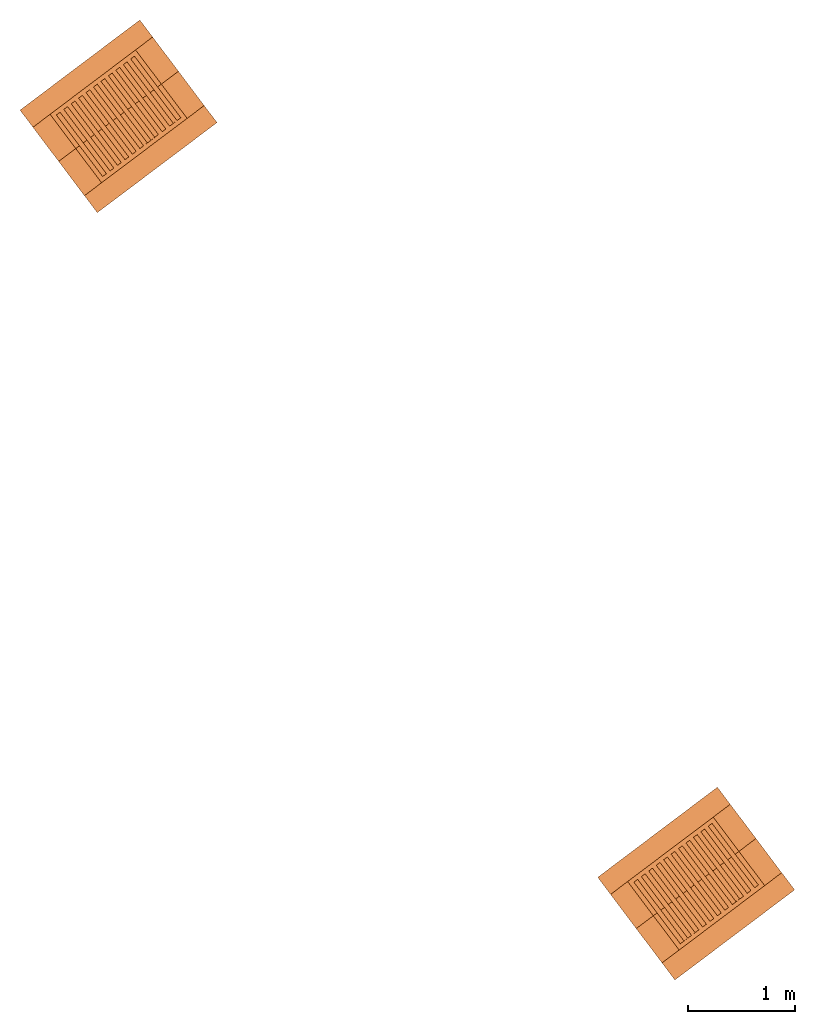
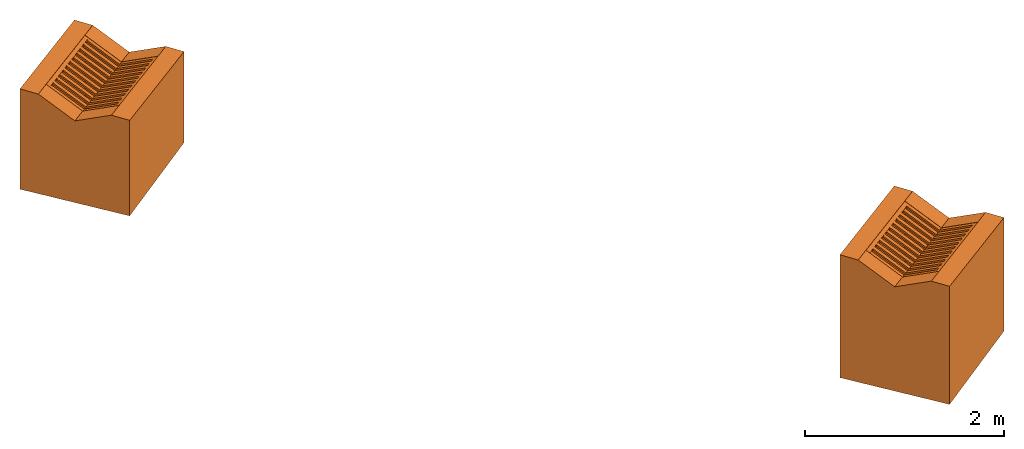
"""IFC2X3 building model written with IfcOpenShell, lengths in metres."""

from ifc_helpers import new_model, entity, si_unit, converted_unit, direction, frame, origin_with_axes, place, context, project, spatial, faceted_brep, element, save


model = new_model("IFC2X3")

# Units and contexts
model_context = context("Model", 3, precision=1e-05, world=origin_with_axes(), true_north=direction((0.0, 1.0)))
ifc_project = project(units=[si_unit("LENGTHUNIT", "METRE"), converted_unit("PLANEANGLEUNIT", "Degree", entity("IfcPlaneAngleMeasure", 0.015707963), si_unit("PLANEANGLEUNIT", "RADIAN"), dimensions=[0, 0, 0, 0, 0, 0, 0]), si_unit("AREAUNIT", "SQUARE_METRE"), si_unit("VOLUMEUNIT", "CUBIC_METRE"), si_unit("MASSUNIT", "GRAM", prefix="KILO")], contexts=[model_context])

# Site, building, storeys
site_placement = place(None, frame((0.0, 0.0, 0.0), z_axis=(0.0, 0.0, 1.0), x_axis=(1.0, 6.12323399573677e-17, 0.0)))
site = spatial("IfcSite", under=ifc_project, at=site_placement, CompositionType="ELEMENT")
building_placement = place(None, frame((0.0, 0.0, 0.0), z_axis=(0.0, 0.0, 1.0), x_axis=(1.0, 6.12323399573677e-17, 0.0)))
building = spatial("IfcBuilding", under=site, at=building_placement, Name="(G0) Grupo 0", CompositionType="ELEMENT")
storey_1_placement = place(building_placement, origin_with_axes())
storey_1 = spatial("IfcBuildingStorey", under=building, at=storey_1_placement, Name="(E2)", CompositionType="ELEMENT")
storey_2_placement = place(storey_1_placement, origin_with_axes())
storey_2 = spatial("IfcBuildingStorey", under=storey_1, at=storey_2_placement, CompositionType="PARTIAL")
storey_3_placement = place(storey_2_placement, origin_with_axes())
storey_3 = spatial("IfcBuildingStorey", under=storey_2, at=storey_3_placement, CompositionType="PARTIAL")

# Proxies
proxy_1_placement = place(storey_3_placement, frame((13.447, -4.29, 174.55), z_axis=(0.0, 0.0, 1.0), x_axis=(1.0, 0.0, 0.0)))
element("IfcBuildingElementProxy", 1, at=proxy_1_placement, inside=storey_3, Name="P1", CompositionType="ELEMENT", context=model_context, shape_type="Brep", body=[
    faceted_brep([(1.118, 1.801, 0.2), (1.238, 1.641, 0.2), (1.238, 1.641, 1.445), (1.118, 1.801, 1.455), (1.118, 1.801, 0.0), (1.238, 1.641, 0.0), (1.079, 1.521, 1.453), (1.079, 1.521, 0.2), (1.479, 1.322, 0.2), (1.479, 1.322, 1.225), (1.479, 1.322, 0.0), (1.319, 1.201, 1.233), (1.319, 1.201, 0.2), (1.719, 1.002, 0.2), (1.719, 1.002, 1.405), (1.719, 1.002, 0.0), (1.56, 0.882, 1.413), (1.56, 0.882, 0.2), (1.84, 0.842, 0.2), (1.84, 0.842, 1.395), (1.84, 0.842, 0.0), (0.721, 0.0, 0.2), (0.721, 0.0, 1.451), (0.721, 0.0, 0.0), (0.761, 0.28, 1.453), (0.761, 0.28, 0.2), (0.601, 0.16, 0.2), (0.601, 0.16, 1.461), (0.601, 0.16, 0.0), (0.36, 0.48, 0.2), (0.36, 0.48, 1.281), (0.36, 0.48, 0.0), (0.52, 0.6, 1.273), (0.52, 0.6, 0.2), (0.12, 0.799, 0.2), (0.12, 0.799, 1.501), (0.12, 0.799, 0.0), (0.28, 0.92, 1.493), (0.28, 0.92, 0.2), (0.0, 0.959, 0.2), (0.0, 0.959, 1.511), (0.0, 0.959, 0.0), (0.92, 0.901, 0.0), (0.92, 0.901, 0.2)], [[[0, 1, 2, 3]], [[4, 5, 1, 0]], [[6, 7, 7, 6]], [[2, 6, 6, 3]], [[1, 8, 9, 2]], [[5, 10, 8, 1]], [[11, 12, 7, 6]], [[9, 11, 6, 2]], [[8, 13, 14, 9]], [[10, 15, 13, 8]], [[16, 17, 12, 11]], [[14, 16, 11, 9]], [[13, 18, 19, 14]], [[15, 20, 18, 13]], [[16, 17, 17, 16]], [[19, 16, 16, 14]], [[18, 21, 22, 19]], [[20, 23, 21, 18]], [[24, 25, 17, 16]], [[22, 24, 16, 19]], [[21, 26, 27, 22]], [[23, 28, 26, 21]], [[24, 25, 25, 24]], [[27, 24, 24, 22]], [[26, 29, 30, 27]], [[28, 31, 29, 26]], [[32, 33, 25, 24]], [[30, 32, 24, 27]], [[29, 34, 35, 30]], [[31, 36, 34, 29]], [[37, 38, 33, 32]], [[35, 37, 32, 30]], [[34, 39, 40, 35]], [[36, 41, 39, 34]], [[37, 38, 38, 37]], [[40, 37, 37, 35]], [[39, 0, 3, 40]], [[41, 4, 0, 39]], [[6, 7, 38, 37]], [[3, 6, 37, 40]], [[42, 5, 4]], [[43, 7, 12]], [[42, 10, 5]], [[43, 12, 17]], [[42, 15, 10]], [[42, 20, 15]], [[43, 17, 25]], [[42, 23, 20]], [[42, 28, 23]], [[43, 25, 33]], [[42, 31, 28]], [[43, 33, 38]], [[42, 36, 31]], [[42, 41, 36]], [[43, 38, 7]], [[42, 4, 41]]], orient=[[False], [False], [False], [False], [False], [False], [False], [False], [False], [False], [False], [False], [False], [False], [False], [False], [False], [False], [False], [False], [False], [False], [False], [False], [False], [False], [False], [False], [False], [False], [False], [False], [False], [False], [False], [False], [False], [False], [False], [False], [False], [False], [False], [False], [False], [False], [False], [False], [False], [False], [False], [False], [False], [False], [False], [False]]),
])
proxy_2_placement = place(storey_3_placement, frame((13.727, -4.01, 175.761), z_axis=(0.0, 0.0, 1.0), x_axis=(1.0, 0.0, 0.0)))
element("IfcBuildingElementProxy", 2, at=proxy_2_placement, inside=storey_3, Name="P1 (Rejilla)", ObjectType="REJILLA", CompositionType="ELEMENT", context=model_context, shape_type="Brep", body=[
    faceted_brep([(1.256, 0.634, 0.182), (1.256, 0.634, 0.162), (1.28, 0.602, 0.18), (1.28, 0.602, 0.2), (0.481, 0.0, 0.22), (0.457, 0.032, 0.202), (0.457, 0.032, 0.222), (0.481, 0.0, 0.24), (0.799, 1.241, 0.24), (0.799, 1.241, 0.22), (0.823, 1.209, 0.198), (0.823, 1.209, 0.218), (0.024, 0.608, 0.238), (0.0, 0.64, 0.26), (0.0, 0.64, 0.28), (0.024, 0.608, 0.258), (1.004, 0.895, 0.02), (1.004, 0.895, 0.0), (1.039, 0.921, 0.0), (1.039, 0.921, 0.02), (1.221, 0.608, 0.162), (1.221, 0.608, 0.182), (0.788, 1.183, 0.218), (0.788, 1.183, 0.198), (0.935, 0.843, 0.023), (0.935, 0.843, 0.003), (0.97, 0.869, 0.003), (0.97, 0.869, 0.023), (1.186, 0.582, 0.165), (1.151, 0.555, 0.165), (1.151, 0.555, 0.185), (1.186, 0.582, 0.185), (0.718, 1.131, 0.221), (0.718, 1.131, 0.201), (0.753, 1.157, 0.201), (0.753, 1.157, 0.221), (0.865, 0.791, 0.027), (0.865, 0.791, 0.007), (0.9, 0.817, 0.007), (0.9, 0.817, 0.027), (1.117, 0.529, 0.169), (1.082, 0.503, 0.169), (1.082, 0.503, 0.189), (1.117, 0.529, 0.189), (0.649, 1.078, 0.225), (0.649, 1.078, 0.205), (0.684, 1.104, 0.205), (0.684, 1.104, 0.225), (0.796, 0.738, 0.03), (0.796, 0.738, 0.01), (0.831, 0.765, 0.01), (0.831, 0.765, 0.03), (1.047, 0.477, 0.172), (1.012, 0.451, 0.172), (1.012, 0.451, 0.192), (1.047, 0.477, 0.192), (0.579, 1.026, 0.228), (0.579, 1.026, 0.208), (0.614, 1.052, 0.208), (0.614, 1.052, 0.228), (0.726, 0.686, 0.034), (0.726, 0.686, 0.014), (0.761, 0.712, 0.014), (0.761, 0.712, 0.034), (0.978, 0.425, 0.176), (0.943, 0.398, 0.176), (0.943, 0.398, 0.196), (0.978, 0.425, 0.196), (0.51, 0.974, 0.232), (0.51, 0.974, 0.212), (0.545, 1.0, 0.212), (0.545, 1.0, 0.232), (0.657, 0.634, 0.037), (0.657, 0.634, 0.017), (0.692, 0.66, 0.017), (0.692, 0.66, 0.037), (0.908, 0.372, 0.179), (0.874, 0.346, 0.179), (0.874, 0.346, 0.199), (0.908, 0.372, 0.199), (0.44, 0.921, 0.235), (0.44, 0.921, 0.215), (0.475, 0.948, 0.215), (0.475, 0.948, 0.235), (0.588, 0.581, 0.041), (0.588, 0.581, 0.021), (0.622, 0.608, 0.021), (0.622, 0.608, 0.041), (0.839, 0.32, 0.183), (0.804, 0.294, 0.183), (0.804, 0.294, 0.203), (0.839, 0.32, 0.203), (0.371, 0.869, 0.239), (0.371, 0.869, 0.219), (0.406, 0.895, 0.219), (0.406, 0.895, 0.239), (0.518, 0.529, 0.044), (0.518, 0.529, 0.024), (0.553, 0.555, 0.024), (0.553, 0.555, 0.044), (0.769, 0.268, 0.186), (0.735, 0.242, 0.186), (0.735, 0.242, 0.206), (0.769, 0.268, 0.206), (0.302, 0.817, 0.242), (0.302, 0.817, 0.222), (0.336, 0.843, 0.222), (0.336, 0.843, 0.242), (0.449, 0.477, 0.048), (0.449, 0.477, 0.028), (0.483, 0.503, 0.028), (0.483, 0.503, 0.048), (0.7, 0.215, 0.19), (0.665, 0.189, 0.19), (0.665, 0.189, 0.21), (0.7, 0.215, 0.21), (0.232, 0.765, 0.246), (0.232, 0.765, 0.226), (0.267, 0.791, 0.226), (0.267, 0.791, 0.246), (0.379, 0.425, 0.051), (0.379, 0.425, 0.031), (0.414, 0.451, 0.031), (0.414, 0.451, 0.051), (0.63, 0.163, 0.193), (0.596, 0.137, 0.193), (0.596, 0.137, 0.213), (0.63, 0.163, 0.213), (0.163, 0.712, 0.249), (0.163, 0.712, 0.229), (0.197, 0.738, 0.229), (0.197, 0.738, 0.249), (0.31, 0.372, 0.055), (0.31, 0.372, 0.035), (0.344, 0.398, 0.035), (0.344, 0.398, 0.055), (0.561, 0.111, 0.197), (0.526, 0.085, 0.197), (0.526, 0.085, 0.217), (0.561, 0.111, 0.217), (0.093, 0.66, 0.253), (0.093, 0.66, 0.233), (0.128, 0.686, 0.233), (0.128, 0.686, 0.253), (0.24, 0.32, 0.058), (0.24, 0.32, 0.038), (0.275, 0.346, 0.038), (0.275, 0.346, 0.058), (0.491, 0.059, 0.2), (0.457, 0.032, 0.2), (0.457, 0.032, 0.22), (0.491, 0.059, 0.22), (0.024, 0.608, 0.256), (0.024, 0.608, 0.236), (0.058, 0.634, 0.236), (0.058, 0.634, 0.256)], [[[0, 1, 2, 3]], [[4, 5, 6, 7]], [[7, 6, 0, 3]], [[1, 5, 4, 2]], [[6, 5, 1, 0]], [[2, 4, 7, 3]], [[8, 9, 10, 11]], [[12, 13, 14, 15]], [[15, 14, 8, 11]], [[9, 13, 12, 10]], [[14, 13, 9, 8]], [[10, 12, 15, 11]], [[16, 17, 18, 19]], [[1, 20, 21, 0]], [[0, 21, 16, 19]], [[17, 20, 1, 18]], [[21, 20, 17, 16]], [[18, 1, 0, 19]], [[22, 23, 10, 11]], [[18, 17, 16, 19]], [[19, 16, 22, 11]], [[23, 17, 18, 10]], [[16, 17, 23, 22]], [[10, 18, 19, 11]], [[24, 25, 26, 27]], [[28, 29, 30, 31]], [[31, 30, 24, 27]], [[25, 29, 28, 26]], [[30, 29, 25, 24]], [[26, 28, 31, 27]], [[32, 33, 34, 35]], [[26, 25, 24, 27]], [[27, 24, 32, 35]], [[33, 25, 26, 34]], [[24, 25, 33, 32]], [[34, 26, 27, 35]], [[36, 37, 38, 39]], [[40, 41, 42, 43]], [[43, 42, 36, 39]], [[37, 41, 40, 38]], [[42, 41, 37, 36]], [[38, 40, 43, 39]], [[44, 45, 46, 47]], [[38, 37, 36, 39]], [[39, 36, 44, 47]], [[45, 37, 38, 46]], [[36, 37, 45, 44]], [[46, 38, 39, 47]], [[48, 49, 50, 51]], [[52, 53, 54, 55]], [[55, 54, 48, 51]], [[49, 53, 52, 50]], [[54, 53, 49, 48]], [[50, 52, 55, 51]], [[56, 57, 58, 59]], [[50, 49, 48, 51]], [[51, 48, 56, 59]], [[57, 49, 50, 58]], [[48, 49, 57, 56]], [[58, 50, 51, 59]], [[60, 61, 62, 63]], [[64, 65, 66, 67]], [[67, 66, 60, 63]], [[61, 65, 64, 62]], [[66, 65, 61, 60]], [[62, 64, 67, 63]], [[68, 69, 70, 71]], [[62, 61, 60, 63]], [[63, 60, 68, 71]], [[69, 61, 62, 70]], [[60, 61, 69, 68]], [[70, 62, 63, 71]], [[72, 73, 74, 75]], [[76, 77, 78, 79]], [[79, 78, 72, 75]], [[73, 77, 76, 74]], [[78, 77, 73, 72]], [[74, 76, 79, 75]], [[80, 81, 82, 83]], [[74, 73, 72, 75]], [[75, 72, 80, 83]], [[81, 73, 74, 82]], [[72, 73, 81, 80]], [[82, 74, 75, 83]], [[84, 85, 86, 87]], [[88, 89, 90, 91]], [[91, 90, 84, 87]], [[85, 89, 88, 86]], [[90, 89, 85, 84]], [[86, 88, 91, 87]], [[92, 93, 94, 95]], [[86, 85, 84, 87]], [[87, 84, 92, 95]], [[93, 85, 86, 94]], [[84, 85, 93, 92]], [[94, 86, 87, 95]], [[96, 97, 98, 99]], [[100, 101, 102, 103]], [[103, 102, 96, 99]], [[97, 101, 100, 98]], [[102, 101, 97, 96]], [[98, 100, 103, 99]], [[104, 105, 106, 107]], [[98, 97, 96, 99]], [[99, 96, 104, 107]], [[105, 97, 98, 106]], [[96, 97, 105, 104]], [[106, 98, 99, 107]], [[108, 109, 110, 111]], [[112, 113, 114, 115]], [[115, 114, 108, 111]], [[109, 113, 112, 110]], [[114, 113, 109, 108]], [[110, 112, 115, 111]], [[116, 117, 118, 119]], [[110, 109, 108, 111]], [[111, 108, 116, 119]], [[117, 109, 110, 118]], [[108, 109, 117, 116]], [[118, 110, 111, 119]], [[120, 121, 122, 123]], [[124, 125, 126, 127]], [[127, 126, 120, 123]], [[121, 125, 124, 122]], [[126, 125, 121, 120]], [[122, 124, 127, 123]], [[128, 129, 130, 131]], [[122, 121, 120, 123]], [[123, 120, 128, 131]], [[129, 121, 122, 130]], [[120, 121, 129, 128]], [[130, 122, 123, 131]], [[132, 133, 134, 135]], [[136, 137, 138, 139]], [[139, 138, 132, 135]], [[133, 137, 136, 134]], [[138, 137, 133, 132]], [[134, 136, 139, 135]], [[140, 141, 142, 143]], [[134, 133, 132, 135]], [[135, 132, 140, 143]], [[141, 133, 134, 142]], [[132, 133, 141, 140]], [[142, 134, 135, 143]], [[144, 145, 146, 147]], [[148, 149, 150, 151]], [[151, 150, 144, 147]], [[145, 149, 148, 146]], [[150, 149, 145, 144]], [[146, 148, 151, 147]], [[152, 153, 154, 155]], [[146, 145, 144, 147]], [[147, 144, 152, 155]], [[153, 145, 146, 154]], [[144, 145, 153, 152]], [[154, 146, 147, 155]]], orient=[[False], [False], [False], [False], [False], [False], [False], [False], [False], [False], [False], [False], [False], [False], [False], [False], [False], [False], [False], [False], [False], [False], [False], [False], [False], [False], [False], [False], [False], [False], [False], [False], [False], [False], [False], [False], [False], [False], [False], [False], [False], [False], [False], [False], [False], [False], [False], [False], [False], [False], [False], [False], [False], [False], [False], [False], [False], [False], [False], [False], [False], [False], [False], [False], [False], [False], [False], [False], [False], [False], [False], [False], [False], [False], [False], [False], [False], [False], [False], [False], [False], [False], [False], [False], [False], [False], [False], [False], [False], [False], [False], [False], [False], [False], [False], [False], [False], [False], [False], [False], [False], [False], [False], [False], [False], [False], [False], [False], [False], [False], [False], [False], [False], [False], [False], [False], [False], [False], [False], [False], [False], [False], [False], [False], [False], [False], [False], [False], [False], [False], [False], [False], [False], [False], [False], [False], [False], [False], [False], [False], [False], [False], [False], [False], [False], [False], [False], [False], [False], [False], [False], [False], [False], [False], [False], [False]]),
])
proxy_3_placement = place(storey_3_placement, frame((8.051, 2.877, 174.41), z_axis=(0.0, 0.0, 1.0), x_axis=(1.0, 0.0, 0.0)))
element("IfcBuildingElementProxy", 3, at=proxy_3_placement, inside=storey_3, Name="P2", CompositionType="ELEMENT", context=model_context, shape_type="Brep", body=[
    faceted_brep([(1.119, 1.8, 0.25), (1.239, 1.641, 0.25), (1.239, 1.641, 1.168), (1.119, 1.8, 1.178), (1.119, 1.8, 0.0), (1.239, 1.641, 0.0), (1.079, 1.52, 1.176), (1.079, 1.52, 0.25), (1.48, 1.321, 0.25), (1.48, 1.321, 0.948), (1.48, 1.321, 0.0), (1.32, 1.201, 0.956), (1.32, 1.201, 0.25), (1.72, 1.001, 0.25), (1.72, 1.001, 1.128), (1.72, 1.001, 0.0), (1.561, 0.881, 1.136), (1.561, 0.881, 0.25), (1.841, 0.842, 0.25), (1.841, 0.842, 1.118), (1.841, 0.842, 0.0), (0.722, 0.0, 0.25), (0.722, 0.0, 1.174), (0.722, 0.0, 0.0), (0.762, 0.28, 1.176), (0.762, 0.28, 0.25), (0.602, 0.159, 0.25), (0.602, 0.159, 1.184), (0.602, 0.159, 0.0), (0.361, 0.479, 0.25), (0.361, 0.479, 1.004), (0.361, 0.479, 0.0), (0.521, 0.599, 0.996), (0.521, 0.599, 0.25), (0.121, 0.798, 0.25), (0.121, 0.798, 1.224), (0.121, 0.798, 0.0), (0.281, 0.919, 1.216), (0.281, 0.919, 0.25), (0.0, 0.958, 0.25), (0.0, 0.958, 1.234), (0.0, 0.958, 0.0), (0.921, 0.9, 0.0), (0.921, 0.9, 0.25)], [[[0, 1, 2, 3]], [[4, 5, 1, 0]], [[6, 7, 7, 6]], [[2, 6, 6, 3]], [[1, 8, 9, 2]], [[5, 10, 8, 1]], [[11, 12, 7, 6]], [[9, 11, 6, 2]], [[8, 13, 14, 9]], [[10, 15, 13, 8]], [[16, 17, 12, 11]], [[14, 16, 11, 9]], [[13, 18, 19, 14]], [[15, 20, 18, 13]], [[16, 17, 17, 16]], [[19, 16, 16, 14]], [[18, 21, 22, 19]], [[20, 23, 21, 18]], [[24, 25, 17, 16]], [[22, 24, 16, 19]], [[21, 26, 27, 22]], [[23, 28, 26, 21]], [[24, 25, 25, 24]], [[27, 24, 24, 22]], [[26, 29, 30, 27]], [[28, 31, 29, 26]], [[32, 33, 25, 24]], [[30, 32, 24, 27]], [[29, 34, 35, 30]], [[31, 36, 34, 29]], [[37, 38, 33, 32]], [[35, 37, 32, 30]], [[34, 39, 40, 35]], [[36, 41, 39, 34]], [[37, 38, 38, 37]], [[40, 37, 37, 35]], [[39, 0, 3, 40]], [[41, 4, 0, 39]], [[6, 7, 38, 37]], [[3, 6, 37, 40]], [[42, 5, 4]], [[43, 7, 12]], [[42, 10, 5]], [[43, 12, 17]], [[42, 15, 10]], [[42, 20, 15]], [[43, 17, 25]], [[42, 23, 20]], [[42, 28, 23]], [[43, 25, 33]], [[42, 31, 28]], [[43, 33, 38]], [[42, 36, 31]], [[42, 41, 36]], [[43, 38, 7]], [[42, 4, 41]]], orient=[[False], [False], [False], [False], [False], [False], [False], [False], [False], [False], [False], [False], [False], [False], [False], [False], [False], [False], [False], [False], [False], [False], [False], [False], [False], [False], [False], [False], [False], [False], [False], [False], [False], [False], [False], [False], [False], [False], [False], [False], [False], [False], [False], [False], [False], [False], [False], [False], [False], [False], [False], [False], [False], [False], [False], [False]]),
])
proxy_4_placement = place(storey_3_placement, frame((8.332, 3.157, 175.344), z_axis=(0.0, 0.0, 1.0), x_axis=(1.0, 0.0, 0.0)))
element("IfcBuildingElementProxy", 4, at=proxy_4_placement, inside=storey_3, Name="P2 (Rejilla)", ObjectType="REJILLA", CompositionType="ELEMENT", context=model_context, shape_type="Brep", body=[
    faceted_brep([(1.256, 0.633, 0.182), (1.256, 0.633, 0.162), (1.28, 0.601, 0.18), (1.28, 0.601, 0.2), (0.481, 0.0, 0.22), (0.457, 0.032, 0.202), (0.457, 0.032, 0.222), (0.481, 0.0, 0.24), (0.798, 1.24, 0.24), (0.798, 1.24, 0.22), (0.823, 1.208, 0.198), (0.823, 1.208, 0.218), (0.024, 0.607, 0.238), (0.0, 0.639, 0.26), (0.0, 0.639, 0.28), (0.024, 0.607, 0.258), (1.004, 0.895, 0.02), (1.004, 0.895, 0.0), (1.039, 0.921, 0.0), (1.039, 0.921, 0.02), (1.221, 0.607, 0.162), (1.221, 0.607, 0.182), (0.788, 1.182, 0.218), (0.788, 1.182, 0.198), (0.935, 0.842, 0.023), (0.935, 0.842, 0.003), (0.97, 0.868, 0.003), (0.97, 0.868, 0.023), (1.186, 0.581, 0.165), (1.151, 0.555, 0.165), (1.151, 0.555, 0.185), (1.186, 0.581, 0.185), (0.718, 1.13, 0.221), (0.718, 1.13, 0.201), (0.753, 1.156, 0.201), (0.753, 1.156, 0.221), (0.865, 0.79, 0.026), (0.865, 0.79, 0.006), (0.9, 0.816, 0.006), (0.9, 0.816, 0.026), (1.117, 0.528, 0.168), (1.082, 0.502, 0.168), (1.082, 0.502, 0.188), (1.117, 0.528, 0.188), (0.649, 1.078, 0.224), (0.649, 1.078, 0.204), (0.684, 1.104, 0.204), (0.684, 1.104, 0.224), (0.796, 0.738, 0.03), (0.796, 0.738, 0.01), (0.831, 0.764, 0.01), (0.831, 0.764, 0.03), (1.047, 0.476, 0.172), (1.012, 0.45, 0.172), (1.012, 0.45, 0.192), (1.047, 0.476, 0.192), (0.579, 1.025, 0.228), (0.579, 1.025, 0.208), (0.614, 1.051, 0.208), (0.614, 1.051, 0.228), (0.726, 0.685, 0.033), (0.726, 0.685, 0.013), (0.761, 0.711, 0.013), (0.761, 0.711, 0.033), (0.978, 0.424, 0.175), (0.943, 0.398, 0.175), (0.943, 0.398, 0.195), (0.978, 0.424, 0.195), (0.51, 0.973, 0.231), (0.51, 0.973, 0.211), (0.545, 0.999, 0.211), (0.545, 0.999, 0.231), (0.657, 0.633, 0.037), (0.657, 0.633, 0.017), (0.692, 0.659, 0.017), (0.692, 0.659, 0.037), (0.908, 0.372, 0.179), (0.873, 0.345, 0.179), (0.873, 0.345, 0.199), (0.908, 0.372, 0.199), (0.44, 0.921, 0.235), (0.44, 0.921, 0.215), (0.475, 0.947, 0.215), (0.475, 0.947, 0.235), (0.588, 0.581, 0.04), (0.588, 0.581, 0.02), (0.622, 0.607, 0.02), (0.622, 0.607, 0.04), (0.839, 0.319, 0.182), (0.804, 0.293, 0.182), (0.804, 0.293, 0.202), (0.839, 0.319, 0.202), (0.371, 0.868, 0.238), (0.371, 0.868, 0.218), (0.406, 0.894, 0.218), (0.406, 0.894, 0.238), (0.518, 0.528, 0.044), (0.518, 0.528, 0.024), (0.553, 0.555, 0.024), (0.553, 0.555, 0.044), (0.769, 0.267, 0.186), (0.735, 0.241, 0.186), (0.735, 0.241, 0.206), (0.769, 0.267, 0.206), (0.302, 0.816, 0.242), (0.302, 0.816, 0.222), (0.336, 0.842, 0.222), (0.336, 0.842, 0.242), (0.449, 0.476, 0.047), (0.449, 0.476, 0.027), (0.483, 0.502, 0.027), (0.483, 0.502, 0.047), (0.7, 0.215, 0.189), (0.665, 0.188, 0.189), (0.665, 0.188, 0.209), (0.7, 0.215, 0.209), (0.232, 0.764, 0.245), (0.232, 0.764, 0.225), (0.267, 0.79, 0.225), (0.267, 0.79, 0.245), (0.379, 0.424, 0.051), (0.379, 0.424, 0.031), (0.414, 0.45, 0.031), (0.414, 0.45, 0.051), (0.63, 0.162, 0.193), (0.596, 0.136, 0.193), (0.596, 0.136, 0.213), (0.63, 0.162, 0.213), (0.163, 0.711, 0.249), (0.163, 0.711, 0.229), (0.197, 0.738, 0.229), (0.197, 0.738, 0.249), (0.31, 0.372, 0.054), (0.31, 0.372, 0.034), (0.344, 0.398, 0.034), (0.344, 0.398, 0.054), (0.561, 0.11, 0.196), (0.526, 0.084, 0.196), (0.526, 0.084, 0.216), (0.561, 0.11, 0.216), (0.093, 0.659, 0.252), (0.093, 0.659, 0.232), (0.128, 0.685, 0.232), (0.128, 0.685, 0.252), (0.24, 0.319, 0.058), (0.24, 0.319, 0.038), (0.275, 0.345, 0.038), (0.275, 0.345, 0.058), (0.491, 0.058, 0.2), (0.457, 0.032, 0.2), (0.457, 0.032, 0.22), (0.491, 0.058, 0.22), (0.024, 0.607, 0.256), (0.024, 0.607, 0.236), (0.058, 0.633, 0.236), (0.058, 0.633, 0.256)], [[[0, 1, 2, 3]], [[4, 5, 6, 7]], [[7, 6, 0, 3]], [[1, 5, 4, 2]], [[6, 5, 1, 0]], [[2, 4, 7, 3]], [[8, 9, 10, 11]], [[12, 13, 14, 15]], [[15, 14, 8, 11]], [[9, 13, 12, 10]], [[14, 13, 9, 8]], [[10, 12, 15, 11]], [[16, 17, 18, 19]], [[1, 20, 21, 0]], [[0, 21, 16, 19]], [[17, 20, 1, 18]], [[21, 20, 17, 16]], [[18, 1, 0, 19]], [[22, 23, 10, 11]], [[18, 17, 16, 19]], [[19, 16, 22, 11]], [[23, 17, 18, 10]], [[16, 17, 23, 22]], [[10, 18, 19, 11]], [[24, 25, 26, 27]], [[28, 29, 30, 31]], [[31, 30, 24, 27]], [[25, 29, 28, 26]], [[30, 29, 25, 24]], [[26, 28, 31, 27]], [[32, 33, 34, 35]], [[26, 25, 24, 27]], [[27, 24, 32, 35]], [[33, 25, 26, 34]], [[24, 25, 33, 32]], [[34, 26, 27, 35]], [[36, 37, 38, 39]], [[40, 41, 42, 43]], [[43, 42, 36, 39]], [[37, 41, 40, 38]], [[42, 41, 37, 36]], [[38, 40, 43, 39]], [[44, 45, 46, 47]], [[38, 37, 36, 39]], [[39, 36, 44, 47]], [[45, 37, 38, 46]], [[36, 37, 45, 44]], [[46, 38, 39, 47]], [[48, 49, 50, 51]], [[52, 53, 54, 55]], [[55, 54, 48, 51]], [[49, 53, 52, 50]], [[54, 53, 49, 48]], [[50, 52, 55, 51]], [[56, 57, 58, 59]], [[50, 49, 48, 51]], [[51, 48, 56, 59]], [[57, 49, 50, 58]], [[48, 49, 57, 56]], [[58, 50, 51, 59]], [[60, 61, 62, 63]], [[64, 65, 66, 67]], [[67, 66, 60, 63]], [[61, 65, 64, 62]], [[66, 65, 61, 60]], [[62, 64, 67, 63]], [[68, 69, 70, 71]], [[62, 61, 60, 63]], [[63, 60, 68, 71]], [[69, 61, 62, 70]], [[60, 61, 69, 68]], [[70, 62, 63, 71]], [[72, 73, 74, 75]], [[76, 77, 78, 79]], [[79, 78, 72, 75]], [[73, 77, 76, 74]], [[78, 77, 73, 72]], [[74, 76, 79, 75]], [[80, 81, 82, 83]], [[74, 73, 72, 75]], [[75, 72, 80, 83]], [[81, 73, 74, 82]], [[72, 73, 81, 80]], [[82, 74, 75, 83]], [[84, 85, 86, 87]], [[88, 89, 90, 91]], [[91, 90, 84, 87]], [[85, 89, 88, 86]], [[90, 89, 85, 84]], [[86, 88, 91, 87]], [[92, 93, 94, 95]], [[86, 85, 84, 87]], [[87, 84, 92, 95]], [[93, 85, 86, 94]], [[84, 85, 93, 92]], [[94, 86, 87, 95]], [[96, 97, 98, 99]], [[100, 101, 102, 103]], [[103, 102, 96, 99]], [[97, 101, 100, 98]], [[102, 101, 97, 96]], [[98, 100, 103, 99]], [[104, 105, 106, 107]], [[98, 97, 96, 99]], [[99, 96, 104, 107]], [[105, 97, 98, 106]], [[96, 97, 105, 104]], [[106, 98, 99, 107]], [[108, 109, 110, 111]], [[112, 113, 114, 115]], [[115, 114, 108, 111]], [[109, 113, 112, 110]], [[114, 113, 109, 108]], [[110, 112, 115, 111]], [[116, 117, 118, 119]], [[110, 109, 108, 111]], [[111, 108, 116, 119]], [[117, 109, 110, 118]], [[108, 109, 117, 116]], [[118, 110, 111, 119]], [[120, 121, 122, 123]], [[124, 125, 126, 127]], [[127, 126, 120, 123]], [[121, 125, 124, 122]], [[126, 125, 121, 120]], [[122, 124, 127, 123]], [[128, 129, 130, 131]], [[122, 121, 120, 123]], [[123, 120, 128, 131]], [[129, 121, 122, 130]], [[120, 121, 129, 128]], [[130, 122, 123, 131]], [[132, 133, 134, 135]], [[136, 137, 138, 139]], [[139, 138, 132, 135]], [[133, 137, 136, 134]], [[138, 137, 133, 132]], [[134, 136, 139, 135]], [[140, 141, 142, 143]], [[134, 133, 132, 135]], [[135, 132, 140, 143]], [[141, 133, 134, 142]], [[132, 133, 141, 140]], [[142, 134, 135, 143]], [[144, 145, 146, 147]], [[148, 149, 150, 151]], [[151, 150, 144, 147]], [[145, 149, 148, 146]], [[150, 149, 145, 144]], [[146, 148, 151, 147]], [[152, 153, 154, 155]], [[146, 145, 144, 147]], [[147, 144, 152, 155]], [[153, 145, 146, 154]], [[144, 145, 153, 152]], [[154, 146, 147, 155]]], orient=[[False], [False], [False], [False], [False], [False], [False], [False], [False], [False], [False], [False], [False], [False], [False], [False], [False], [False], [False], [False], [False], [False], [False], [False], [False], [False], [False], [False], [False], [False], [False], [False], [False], [False], [False], [False], [False], [False], [False], [False], [False], [False], [False], [False], [False], [False], [False], [False], [False], [False], [False], [False], [False], [False], [False], [False], [False], [False], [False], [False], [False], [False], [False], [False], [False], [False], [False], [False], [False], [False], [False], [False], [False], [False], [False], [False], [False], [False], [False], [False], [False], [False], [False], [False], [False], [False], [False], [False], [False], [False], [False], [False], [False], [False], [False], [False], [False], [False], [False], [False], [False], [False], [False], [False], [False], [False], [False], [False], [False], [False], [False], [False], [False], [False], [False], [False], [False], [False], [False], [False], [False], [False], [False], [False], [False], [False], [False], [False], [False], [False], [False], [False], [False], [False], [False], [False], [False], [False], [False], [False], [False], [False], [False], [False], [False], [False], [False], [False], [False], [False], [False], [False], [False], [False], [False], [False]]),
])

save(model, "model.ifc")
